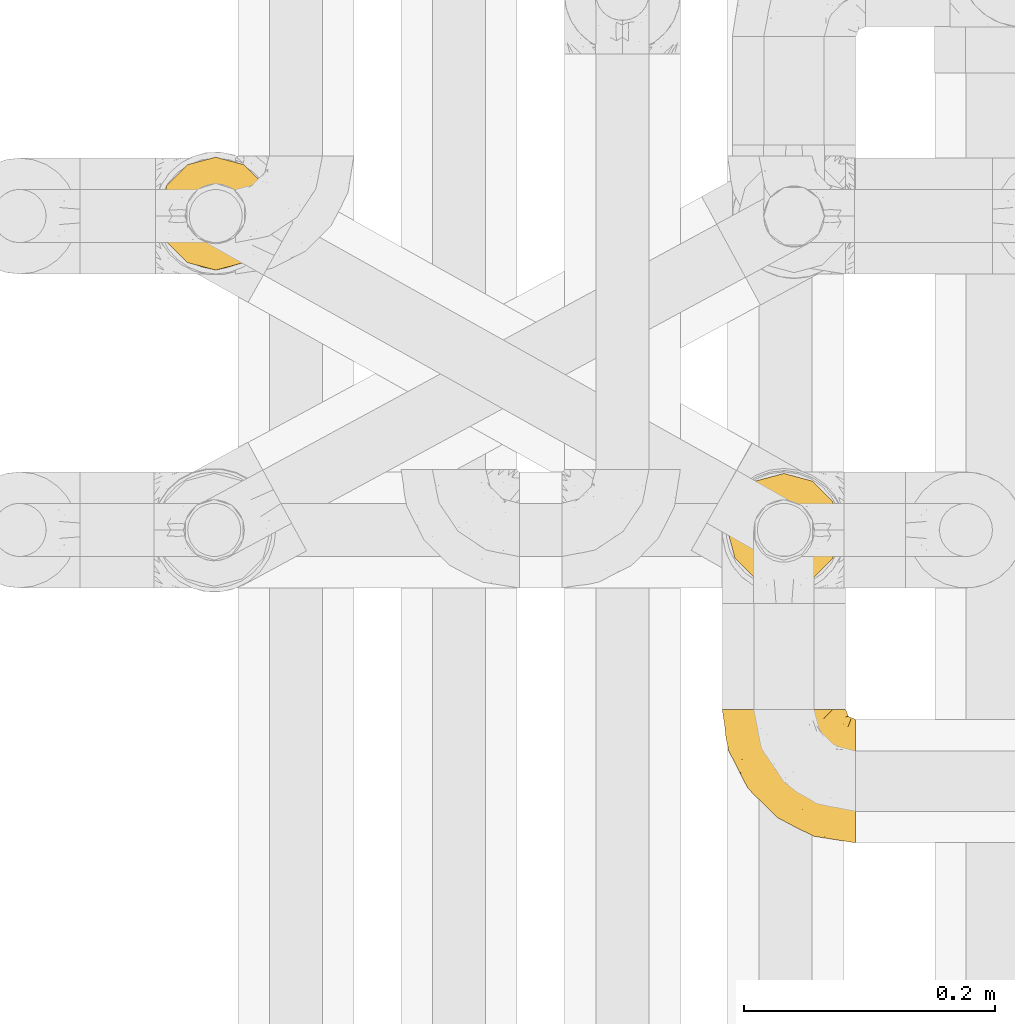
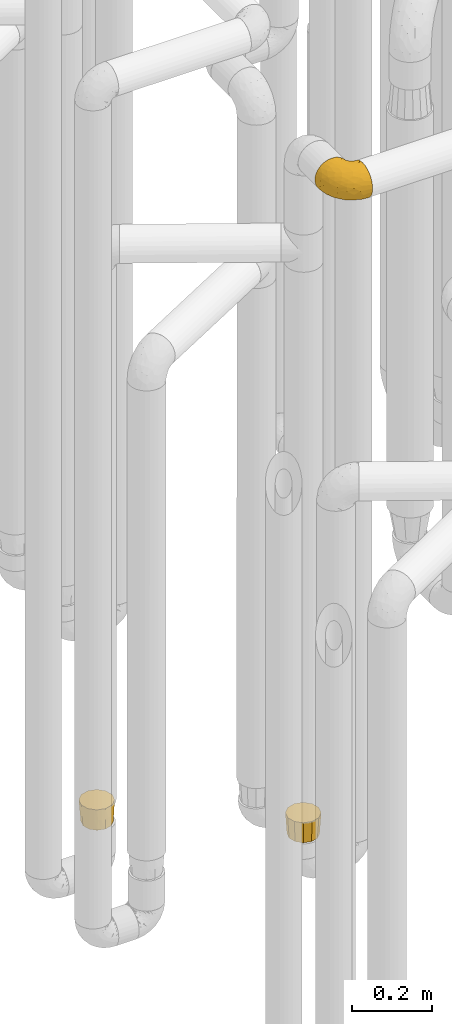
# One storey, part 166 of 827: 3 coverings.
"""IFC2X3 building model written with IfcOpenShell, lengths in millimetres."""

from ifc_helpers import new_model, entity, si_unit, converted_unit, derived_unit, direction, frame, origin, place, context, subcontext, project, spatial, faceted_brep, element, save


model = new_model("IFC2X3")

# Units and contexts
model_context = context("Model", 3, precision=0.01, world=origin(), true_north=direction((6.12303176911189e-17, 1.0)))
body_context = subcontext(model_context, "Body", "Model", "MODEL_VIEW")
ifc_project = project(units=[si_unit("LENGTHUNIT", "METRE", prefix="MILLI"), si_unit("AREAUNIT", "SQUARE_METRE"), si_unit("VOLUMEUNIT", "CUBIC_METRE"), converted_unit("PLANEANGLEUNIT", "DEGREE", entity("IfcRatioMeasure", 0.0174532925199433), si_unit("PLANEANGLEUNIT", "RADIAN"), dimensions=[0, 0, 0, 0, 0, 0, 0]), si_unit("MASSUNIT", "GRAM", prefix="KILO"), derived_unit("MASSDENSITYUNIT", [(si_unit("MASSUNIT", "GRAM", prefix="KILO"), 1), (si_unit("LENGTHUNIT", "METRE"), -3)]), derived_unit("MOMENTOFINERTIAUNIT", [(si_unit("LENGTHUNIT", "METRE"), 4)]), si_unit("TIMEUNIT", "SECOND"), si_unit("FREQUENCYUNIT", "HERTZ"), si_unit("THERMODYNAMICTEMPERATUREUNIT", "DEGREE_CELSIUS"), derived_unit("THERMALTRANSMITTANCEUNIT", [(si_unit("MASSUNIT", "GRAM", prefix="KILO"), 1), (si_unit("THERMODYNAMICTEMPERATUREUNIT", "KELVIN"), -1), (si_unit("TIMEUNIT", "SECOND"), -3)]), derived_unit("VOLUMETRICFLOWRATEUNIT", [(si_unit("LENGTHUNIT", "METRE"), 3), (si_unit("TIMEUNIT", "SECOND"), -1)]), derived_unit("MASSFLOWRATEUNIT", [(si_unit("MASSUNIT", "GRAM", prefix="KILO"), 1), (si_unit("TIMEUNIT", "SECOND"), -1)]), derived_unit("ROTATIONALFREQUENCYUNIT", [(si_unit("TIMEUNIT", "SECOND"), -1)]), si_unit("ELECTRICCURRENTUNIT", "AMPERE"), si_unit("ELECTRICVOLTAGEUNIT", "VOLT"), si_unit("POWERUNIT", "WATT"), si_unit("FORCEUNIT", "NEWTON", prefix="KILO"), si_unit("ILLUMINANCEUNIT", "LUX"), si_unit("LUMINOUSFLUXUNIT", "LUMEN"), si_unit("LUMINOUSINTENSITYUNIT", "CANDELA"), derived_unit("USERDEFINED", [(si_unit("MASSUNIT", "GRAM", prefix="KILO"), -1), (si_unit("LENGTHUNIT", "METRE"), -2), (si_unit("TIMEUNIT", "SECOND"), 3), (si_unit("LUMINOUSFLUXUNIT", "LUMEN"), 1)]), derived_unit("LINEARVELOCITYUNIT", [(si_unit("LENGTHUNIT", "METRE"), 1), (si_unit("TIMEUNIT", "SECOND"), -1)]), si_unit("PRESSUREUNIT", "PASCAL"), derived_unit("USERDEFINED", [(si_unit("LENGTHUNIT", "METRE"), -2), (si_unit("MASSUNIT", "GRAM", prefix="KILO"), 1), (si_unit("TIMEUNIT", "SECOND"), -2)]), derived_unit("LINEARFORCEUNIT", [(si_unit("MASSUNIT", "GRAM", prefix="KILO"), 1), (si_unit("LENGTHUNIT", "METRE"), 1), (si_unit("TIMEUNIT", "SECOND"), -2), (si_unit("LENGTHUNIT", "METRE"), -1)]), derived_unit("PLANARFORCEUNIT", [(si_unit("MASSUNIT", "GRAM", prefix="KILO"), 1), (si_unit("LENGTHUNIT", "METRE"), 1), (si_unit("TIMEUNIT", "SECOND"), -2), (si_unit("LENGTHUNIT", "METRE"), -2)])], contexts=[model_context])

# Site, building, storey
site_placement = place(None, origin())
site = spatial("IfcSite", under=ifc_project, at=site_placement, CompositionType="ELEMENT")
building_placement = place(site_placement, origin())
building = spatial("IfcBuilding", under=site, at=building_placement, CompositionType="ELEMENT")
storey_placement = place(building_placement, frame((0.0, 0.0, 28200.0)))
storey = spatial("IfcBuildingStorey", under=building, at=storey_placement, Name="08", CompositionType="ELEMENT", Elevation=28200.0)

# Coverings
covering_1_placement = place(storey_placement, frame((35678.04, 11305.34, 2549.25)))
element("IfcCovering", 1, at=covering_1_placement, inside=storey, Name=":ADSK_", ObjectType=":ADSK_", PredefinedType="INSULATION", context=body_context, shape_type="Brep", body=[
    faceted_brep([(107.75, 50.75, 99.9), (107.75, 39.8, 98.66), (107.75, 29.41, 95.02), (107.75, 20.09, 89.17), (107.75, 12.31, 81.38), (107.75, 6.46, 72.06), (107.75, 2.83, 61.68), (107.75, 1.6, 50.75), (107.75, 2.83, 39.8), (107.75, 6.47, 29.41), (107.75, 12.32, 20.09), (107.75, 20.11, 12.31), (107.75, 29.43, 6.46), (107.75, 39.81, 2.83), (107.75, 50.75, 1.6), (107.75, 56.45, 2.24), (107.75, 61.69, 2.83), (107.75, 66.88, 4.65), (107.75, 72.08, 6.47), (107.75, 81.4, 12.32), (107.75, 89.18, 20.11), (107.75, 95.03, 29.43), (107.75, 98.66, 39.81), (107.75, 99.9, 50.75), (107.75, 98.66, 61.69), (107.75, 95.02, 72.08), (107.75, 89.17, 81.4), (107.75, 81.38, 89.18), (107.75, 72.06, 95.03), (107.75, 66.87, 96.85), (107.75, 61.68, 98.66), (107.75, 56.45, 99.25), (107.75, 53.6, 99.57), (98.22, 107.75, 38.02), (93.31, 107.75, 26.17), (89.4, 107.75, 21.08), (85.5, 107.75, 15.99), (80.41, 107.75, 12.09), (75.32, 107.75, 8.18), (69.39, 107.75, 5.73), (63.47, 107.75, 3.27), (56.48, 107.75, 2.35), (53.61, 107.75, 1.97), (50.75, 107.75, 1.6), (38.02, 107.75, 3.27), (26.17, 107.75, 8.18), (15.99, 107.75, 15.99), (8.18, 107.75, 26.17), (3.27, 107.75, 38.02), (1.6, 107.75, 50.75), (3.27, 107.75, 63.47), (8.18, 107.75, 75.32), (15.99, 107.75, 85.5), (26.17, 107.75, 93.31), (38.02, 107.75, 98.22), (50.75, 107.75, 99.9), (56.48, 107.75, 99.14), (63.47, 107.75, 98.22), (69.39, 107.75, 95.77), (75.32, 107.75, 93.31), (80.41, 107.75, 89.4), (85.5, 107.75, 85.5), (89.4, 107.75, 80.41), (93.31, 107.75, 75.32), (98.22, 107.75, 63.47), (99.9, 107.75, 50.75), (27.53, 39.38, 59.31), (25.32, 49.75, 73.08), (16.29, 57.38, 63.72), (6.79, 74.94, 50.75), (4.51, 85.97, 58.64), (3.51, 95.66, 50.75), (17.47, 67.82, 76.74), (7.6, 83.09, 67.68), (12.27, 89.16, 78.92), (70.89, 37.01, 94.31), (87.17, 43.46, 98.76), (67.3, 51.79, 98.4), (31.65, 85.58, 94.57), (33.58, 62.84, 89.91), (47.23, 62.77, 96.32), (43.26, 88.17, 98.79), (55.08, 85.93, 99.9), (53.99, 91.42, 99.9), (52.9, 96.91, 99.9), (52.36, 99.62, 99.9), (51.82, 102.33, 99.9), (21.5, 82.57, 87.31), (89.94, 32.75, 95.61), (60.45, 13.79, 60.43), (83.0, 6.77, 65.24), (64.79, 16.46, 72.87), (85.93, 55.08, 99.9), (81.31, 58.17, 99.9), (76.69, 61.26, 99.9), (72.06, 64.35, 99.9), (67.44, 67.44, 99.9), (88.74, 24.18, 90.65), (45.98, 23.37, 63.14), (47.13, 49.76, 91.89), (89.4, 9.84, 75.25), (95.66, 3.51, 50.75), (28.5, 55.75, 82.18), (42.81, 42.34, 85.08), (38.28, 37.78, 76.93), (45.35, 21.87, 50.75), (33.61, 33.61, 50.75), (82.57, 17.1, 83.02), (105.04, 51.28, 99.9), (102.33, 51.82, 99.9), (96.91, 52.9, 99.9), (91.42, 53.99, 99.9), (65.92, 28.01, 87.13), (53.11, 28.99, 80.85), (54.37, 69.9, 99.17), (74.94, 6.79, 50.75), (64.35, 72.06, 99.9), (61.26, 76.69, 99.9), (58.17, 81.31, 99.9), (21.87, 45.35, 50.75), (34.79, 34.79, 67.61), (48.48, 25.72, 72.25), (60.15, 14.33, 50.75), (14.33, 60.15, 50.75), (99.07, 62.38, 98.69), (60.55, 100.57, 99.01), (64.18, 91.06, 98.79), (64.36, 97.66, 98.29), (103.17, 97.55, 68.51), (101.69, 93.65, 76.82), (87.75, 66.85, 98.54), (89.38, 61.93, 99.3), (88.34, 101.4, 83.57), (82.14, 100.07, 89.47), (94.51, 101.36, 75.76), (89.64, 95.94, 84.86), (98.41, 96.3, 75.89), (99.71, 101.98, 64.77), (89.37, 85.88, 90.83), (88.21, 78.88, 94.62), (95.2, 82.8, 90.37), (79.14, 102.58, 91.18), (101.22, 82.88, 88.65), (99.41, 88.57, 84.11), (84.72, 88.67, 91.75), (97.47, 69.08, 96.86), (102.19, 102.19, 50.75), (104.02, 100.06, 58.97), (82.66, 70.56, 98.37), (95.42, 91.07, 83.91), (78.67, 77.56, 97.52), (72.69, 96.59, 95.55), (66.46, 86.38, 98.76), (75.3, 91.79, 95.26), (72.74, 81.71, 98.04), (82.93, 94.11, 90.65), (99.27, 76.09, 93.51), (93.51, 76.91, 94.16), (67.35, 81.44, 99.1), (94.51, 101.37, 25.73), (82.94, 94.12, 10.84), (88.33, 101.41, 17.92), (89.64, 95.96, 16.64), (103.62, 96.22, 30.44), (87.74, 66.85, 2.95), (89.38, 61.94, 2.19), (81.31, 58.17, 1.6), (97.47, 69.1, 4.63), (99.41, 88.58, 17.39), (51.28, 105.04, 1.6), (52.9, 96.91, 1.6), (51.82, 102.33, 1.6), (101.21, 82.9, 12.86), (95.19, 82.82, 11.13), (64.36, 97.66, 3.2), (72.69, 96.59, 5.94), (79.14, 102.58, 10.31), (99.28, 76.13, 8.0), (93.51, 76.93, 7.34), (60.55, 100.57, 2.48), (66.46, 86.38, 2.73), (63.96, 90.86, 2.64), (96.91, 52.9, 1.6), (99.06, 62.39, 2.8), (99.7, 101.98, 36.71), (53.99, 91.42, 1.6), (55.08, 85.93, 1.6), (103.3, 99.49, 38.59), (102.33, 51.82, 1.6), (99.62, 52.36, 1.6), (76.69, 61.26, 1.6), (82.66, 70.56, 3.12), (95.42, 91.09, 17.59), (72.06, 64.35, 1.6), (78.68, 77.6, 3.98), (88.2, 78.89, 6.87), (72.75, 81.71, 3.45), (84.74, 88.69, 9.76), (91.42, 53.99, 1.6), (85.93, 55.08, 1.6), (98.41, 96.31, 25.62), (89.37, 85.9, 10.67), (67.35, 81.45, 2.39), (61.26, 76.69, 1.6), (75.3, 91.79, 6.23), (82.13, 100.07, 12.02), (58.17, 81.31, 1.6), (64.35, 72.06, 1.6), (67.44, 67.44, 1.6), (54.08, 69.6, 2.4), (4.51, 85.97, 42.85), (21.5, 82.57, 14.18), (33.43, 63.16, 11.56), (28.5, 55.81, 19.27), (17.47, 67.81, 24.75), (25.36, 49.73, 28.37), (90.18, 32.55, 5.95), (86.97, 43.23, 2.79), (43.26, 88.17, 2.71), (16.29, 57.38, 37.78), (7.6, 83.08, 33.81), (12.27, 89.16, 22.57), (31.65, 85.58, 6.92), (64.79, 16.46, 28.61), (83.0, 6.77, 36.24), (60.44, 13.8, 41.05), (38.35, 37.71, 24.55), (34.8, 34.8, 33.88), (71.54, 36.83, 7.11), (45.94, 23.39, 38.38), (27.53, 39.38, 42.18), (82.57, 17.12, 18.46), (88.74, 24.19, 10.84), (53.19, 28.89, 20.69), (48.49, 25.69, 29.27), (67.28, 51.77, 3.1), (52.32, 45.66, 9.18), (89.4, 9.85, 26.23), (65.75, 28.11, 14.34), (46.73, 62.27, 5.46), (42.82, 42.35, 16.39)], [[[0, 1, 2, 3, 4, 5, 6, 7, 8, 9, 10, 11, 12, 13, 14, 15, 16, 17, 18, 19, 20, 21, 22, 23, 24, 25, 26, 27, 28, 29, 30, 31, 32]], [[33, 34, 35, 36, 37, 38, 39, 40, 41, 42, 43, 44, 45, 46, 47, 48, 49, 50, 51, 52, 53, 54, 55, 56, 57, 58, 59, 60, 61, 62, 63, 64, 65]], [[66, 67, 68]], [[69, 70, 71]], [[68, 72, 73]], [[73, 72, 74]], [[75, 76, 77]], [[78, 79, 80]], [[51, 50, 73]], [[81, 82, 83, 84, 85, 86, 55]], [[52, 87, 53]], [[74, 52, 51]], [[2, 1, 88]], [[89, 90, 91]], [[77, 92, 93, 94, 95, 96]], [[55, 54, 81]], [[78, 53, 87]], [[5, 90, 6]], [[88, 76, 75]], [[97, 3, 2]], [[89, 91, 98]], [[99, 80, 79]], [[90, 5, 100]], [[74, 87, 52]], [[100, 5, 4]], [[90, 101, 6]], [[79, 102, 103]], [[102, 67, 104]], [[105, 98, 106]], [[107, 4, 3]], [[76, 0, 108, 109, 110, 111, 92]], [[107, 112, 113]], [[114, 77, 96]], [[89, 115, 90]], [[114, 96, 116, 117, 118, 82]], [[75, 97, 88]], [[119, 66, 68]], [[50, 71, 70]], [[100, 91, 90]], [[99, 77, 80]], [[102, 104, 103]], [[97, 107, 3]], [[80, 81, 78]], [[107, 97, 112]], [[68, 73, 70]], [[66, 98, 120]], [[78, 81, 54]], [[114, 81, 80]], [[53, 78, 54]], [[78, 87, 79]], [[102, 87, 72]], [[79, 103, 99]], [[4, 107, 100]], [[91, 100, 107]], [[88, 97, 2]], [[112, 97, 75]], [[99, 112, 75]], [[103, 104, 113]], [[91, 121, 98]], [[89, 105, 122, 115]], [[101, 90, 115]], [[101, 7, 6]], [[88, 1, 76]], [[0, 76, 1]], [[92, 77, 76]], [[73, 74, 51]], [[87, 74, 72]], [[81, 114, 82]], [[77, 114, 80]], [[87, 102, 79]], [[67, 102, 72]], [[68, 67, 72]], [[67, 120, 104]], [[120, 121, 104]], [[104, 121, 113]], [[121, 120, 98]], [[91, 107, 113]], [[91, 113, 121]], [[103, 113, 112]], [[66, 119, 106]], [[105, 89, 98]], [[68, 69, 123, 119]], [[98, 66, 106]], [[66, 120, 67]], [[50, 49, 71]], [[50, 70, 73]], [[112, 99, 103]], [[77, 99, 75]], [[69, 68, 70]], [[29, 124, 110]], [[84, 83, 125]], [[126, 82, 118]], [[59, 58, 127]], [[25, 128, 129]], [[130, 93, 131]], [[132, 62, 133]], [[134, 135, 136]], [[137, 65, 64]], [[64, 134, 137]], [[138, 139, 140]], [[111, 110, 124, 92]], [[134, 136, 137]], [[134, 64, 63]], [[141, 61, 60]], [[125, 58, 57]], [[142, 143, 140]], [[142, 26, 143]], [[127, 83, 82]], [[28, 124, 29]], [[108, 0, 32, 31, 30, 110, 109]], [[30, 29, 110]], [[135, 144, 138]], [[28, 145, 124]], [[57, 56, 55, 86, 85, 84]], [[146, 147, 23]], [[24, 23, 147]], [[25, 143, 26]], [[95, 94, 148]], [[24, 128, 25]], [[149, 138, 143]], [[124, 145, 131]], [[127, 58, 125]], [[150, 148, 139]], [[127, 126, 151]], [[151, 59, 127]], [[152, 151, 126]], [[153, 154, 155]], [[153, 133, 141]], [[145, 28, 27]], [[142, 156, 27]], [[157, 148, 130]], [[61, 133, 62]], [[134, 132, 135]], [[147, 128, 24]], [[65, 137, 146]], [[146, 137, 147]], [[128, 137, 136]], [[137, 128, 147]], [[128, 136, 129]], [[149, 129, 136]], [[25, 129, 143]], [[158, 152, 117]], [[152, 118, 117]], [[153, 151, 152]], [[158, 116, 154]], [[144, 150, 138]], [[153, 152, 158]], [[133, 153, 155]], [[133, 155, 132]], [[141, 60, 151]], [[135, 132, 155]], [[134, 63, 132]], [[144, 135, 155]], [[135, 138, 149]], [[155, 154, 144]], [[150, 154, 96]], [[154, 150, 144]], [[148, 94, 130]], [[82, 126, 127]], [[118, 152, 126]], [[150, 96, 95]], [[139, 148, 157]], [[150, 95, 148]], [[93, 92, 131]], [[130, 145, 156]], [[130, 94, 93]], [[84, 125, 57]], [[127, 125, 83]], [[140, 139, 157]], [[150, 139, 138]], [[140, 157, 142]], [[138, 140, 143]], [[156, 142, 157]], [[27, 26, 142]], [[130, 156, 157]], [[145, 27, 156]], [[132, 63, 62]], [[124, 131, 92]], [[130, 131, 145]], [[129, 149, 143]], [[135, 149, 136]], [[153, 141, 151]], [[59, 151, 60]], [[133, 61, 141]], [[116, 96, 154]], [[153, 158, 154]], [[158, 117, 116]], [[34, 33, 159]], [[160, 161, 162]], [[22, 21, 163]], [[164, 165, 166]], [[19, 18, 167]], [[168, 21, 20]], [[169, 43, 42, 41, 40, 170, 171]], [[172, 173, 168]], [[174, 38, 175]], [[176, 37, 36]], [[177, 164, 178]], [[40, 179, 170]], [[180, 181, 175]], [[17, 182, 183]], [[65, 146, 184]], [[185, 174, 186]], [[23, 22, 187]], [[174, 39, 38]], [[15, 14, 188, 189, 182, 16]], [[179, 40, 39]], [[190, 191, 164]], [[192, 163, 168]], [[33, 184, 159]], [[178, 173, 172]], [[193, 194, 191]], [[18, 183, 167]], [[173, 178, 195]], [[196, 197, 194]], [[198, 199, 183, 182]], [[182, 17, 16]], [[18, 17, 183]], [[200, 159, 184]], [[192, 168, 201]], [[187, 163, 200]], [[202, 203, 180]], [[185, 179, 174]], [[160, 204, 205]], [[206, 181, 180]], [[206, 180, 203]], [[199, 165, 183]], [[165, 164, 167]], [[172, 177, 178]], [[200, 192, 162]], [[205, 161, 160]], [[65, 184, 33]], [[163, 187, 22]], [[175, 204, 180]], [[174, 181, 186]], [[204, 196, 202]], [[197, 160, 162]], [[196, 207, 202]], [[205, 204, 176]], [[196, 204, 160]], [[176, 204, 175]], [[205, 35, 161]], [[34, 159, 161]], [[162, 161, 159]], [[200, 162, 159]], [[197, 162, 201]], [[194, 197, 201]], [[196, 160, 197]], [[191, 195, 178]], [[208, 196, 194]], [[186, 181, 206]], [[175, 181, 174]], [[191, 190, 193]], [[193, 208, 194]], [[195, 194, 201]], [[178, 164, 191]], [[168, 163, 21]], [[166, 165, 199]], [[166, 190, 164]], [[187, 200, 184]], [[184, 146, 187]], [[23, 187, 146]], [[174, 179, 39]], [[170, 179, 185]], [[194, 195, 191]], [[173, 201, 168]], [[201, 173, 195]], [[172, 168, 20]], [[20, 19, 172]], [[177, 172, 19]], [[19, 167, 177]], [[164, 177, 167]], [[35, 205, 36]], [[35, 34, 161]], [[183, 165, 167]], [[162, 192, 201]], [[163, 192, 200]], [[175, 38, 37]], [[205, 176, 36]], [[175, 37, 176]], [[204, 202, 180]], [[207, 196, 208]], [[207, 203, 202]], [[209, 186, 206, 203, 207, 208]], [[48, 210, 71]], [[211, 212, 213]], [[214, 213, 215]], [[216, 217, 13]], [[218, 43, 169, 171, 170, 185, 186]], [[219, 220, 214]], [[47, 46, 221]], [[210, 48, 220]], [[211, 222, 212]], [[222, 45, 44]], [[221, 220, 47]], [[47, 220, 48]], [[221, 211, 214]], [[223, 224, 225]], [[211, 46, 45]], [[226, 227, 215]], [[43, 218, 44]], [[217, 216, 228]], [[227, 229, 230]], [[14, 13, 217]], [[224, 9, 8]], [[10, 231, 11]], [[11, 232, 12]], [[233, 223, 234]], [[235, 208, 193, 190, 166, 199]], [[236, 235, 228]], [[222, 44, 218]], [[106, 230, 229]], [[224, 237, 9]], [[232, 238, 228]], [[9, 237, 10]], [[115, 224, 101]], [[239, 235, 236]], [[232, 11, 231]], [[223, 231, 237]], [[224, 8, 101]], [[223, 229, 234]], [[225, 115, 122, 105]], [[216, 12, 232]], [[209, 235, 239]], [[210, 219, 69]], [[219, 214, 215]], [[230, 119, 219]], [[209, 218, 186]], [[239, 212, 222]], [[239, 222, 218]], [[45, 222, 211]], [[236, 212, 239]], [[213, 212, 240]], [[223, 237, 224]], [[231, 10, 237]], [[238, 232, 231]], [[216, 232, 228]], [[233, 231, 223]], [[236, 238, 240]], [[115, 225, 224]], [[234, 229, 227]], [[8, 7, 101]], [[235, 209, 208]], [[218, 209, 239]], [[217, 228, 235]], [[13, 12, 216]], [[235, 199, 217]], [[217, 199, 198, 182, 189, 188, 14]], [[211, 221, 46]], [[220, 221, 214]], [[71, 210, 69]], [[71, 49, 48]], [[219, 210, 220]], [[226, 215, 213]], [[211, 213, 214]], [[226, 213, 240]], [[215, 227, 230]], [[233, 240, 238]], [[234, 227, 226]], [[233, 234, 226]], [[229, 223, 225]], [[240, 233, 226]], [[233, 238, 231]], [[225, 105, 229]], [[229, 105, 106]], [[106, 119, 230]], [[123, 69, 219, 119]], [[215, 230, 219]], [[238, 236, 228]], [[212, 236, 240]]]),
])
covering_2_placement = place(storey_placement, frame((35682.19, 11509.57, 494.96)))
element("IfcCovering", 2, at=covering_2_placement, inside=storey, Name=":ADSK_", ObjectType=":ADSK_", PredefinedType="INSULATION", context=body_context, shape_type="Brep", body=[
    faceted_brep([(46.6, 87.66, 0.08), (56.85, 84.91, 0.08), (67.1, 82.17, 0.08), (74.6, 74.66, 0.07), (82.1, 67.16, 0.06), (84.85, 56.91, 0.05), (87.6, 46.66, 0.04), (84.85, 36.41, 0.03), (82.1, 26.16, 0.02), (74.6, 18.66, 0.01), (67.1, 11.15, 0.01), (56.85, 8.41, 0.0), (46.6, 5.66, 0.0), (36.35, 8.41, 0.0), (26.1, 11.15, 0.01), (18.59, 18.66, 0.01), (11.09, 26.16, 0.02), (8.34, 36.41, 0.03), (5.6, 46.66, 0.04), (8.34, 56.91, 0.05), (11.09, 67.16, 0.06), (18.59, 74.66, 0.07), (26.1, 82.17, 0.08), (36.35, 84.91, 0.08), (7.62, 24.1, 64.02), (15.86, 15.86, 64.01), (24.1, 7.62, 64.0), (33.21, 5.18, 64.0), (46.6, 1.6, 64.0), (59.99, 5.18, 64.0), (69.1, 7.62, 64.0), (77.33, 15.86, 64.01), (85.57, 24.1, 64.02), (88.01, 33.21, 64.03), (91.6, 46.6, 64.04), (88.01, 59.99, 64.05), (85.57, 69.1, 64.06), (77.33, 77.33, 64.07), (69.1, 85.57, 64.08), (59.99, 88.01, 64.08), (46.6, 91.6, 64.09), (33.21, 88.01, 64.08), (24.1, 85.57, 64.08), (15.86, 77.33, 64.07), (7.62, 69.1, 64.06), (5.18, 59.99, 64.05), (1.6, 46.6, 64.04), (5.18, 33.21, 64.03)], [[[0, 1, 2, 3, 4, 5, 6, 7, 8, 9, 10, 11, 12, 13, 14, 15, 16, 17, 18, 19, 20, 21, 22, 23]], [[24, 25, 26, 27, 28, 29, 30, 31, 32, 33, 34, 35, 36, 37, 38, 39, 40, 41, 42, 43, 44, 45, 46, 47]], [[4, 36, 35, 34, 6, 5]], [[38, 37, 36, 4, 3, 2]], [[1, 0, 40, 39, 38, 2]], [[10, 30, 29, 28, 12, 11]], [[32, 31, 30, 10, 9, 8]], [[7, 6, 34, 33, 32, 8]], [[16, 24, 47, 46, 18, 17]], [[26, 25, 24, 16, 15, 14]], [[13, 12, 28, 27, 26, 14]], [[22, 42, 41, 40, 0, 23]], [[44, 43, 42, 22, 21, 20]], [[19, 18, 46, 45, 44, 20]]]),
])
covering_3_placement = place(storey_placement, frame((35229.64, 11761.53, 540.0)))
element("IfcCovering", 3, at=covering_3_placement, inside=storey, Name=":ADSK_", ObjectType=":ADSK_", PredefinedType="INSULATION", context=body_context, shape_type="Brep", body=[
    faceted_brep([(15.86, 15.86, 64.0), (24.1, 7.62, 64.0), (35.35, 4.61, 64.0), (46.6, 1.6, 64.0), (57.85, 4.61, 64.0), (69.1, 7.62, 64.0), (77.33, 15.86, 64.0), (85.57, 24.1, 64.0), (88.58, 35.35, 64.0), (91.6, 46.6, 64.0), (88.58, 57.85, 64.0), (85.57, 69.1, 64.0), (77.33, 77.33, 64.0), (69.1, 85.57, 64.0), (57.85, 88.58, 64.0), (46.6, 91.6, 64.0), (35.35, 88.58, 64.0), (24.1, 85.57, 64.0), (15.86, 77.33, 64.0), (7.62, 69.1, 64.0), (4.61, 57.85, 64.0), (1.6, 46.6, 64.0), (4.61, 35.35, 64.0), (7.62, 24.1, 64.0), (11.09, 65.17, 0.0), (18.59, 72.67, 0.0), (26.1, 80.18, 0.0), (38.81, 83.58, 0.0), (46.6, 85.67, 0.0), (56.85, 82.92, 0.0), (67.1, 80.18, 0.0), (74.6, 72.67, 0.0), (82.1, 65.17, 0.0), (85.51, 52.46, 0.0), (87.6, 44.67, 0.0), (84.85, 34.42, 0.0), (82.1, 24.17, 0.0), (74.6, 16.67, 0.0), (67.1, 9.16, 0.0), (54.39, 5.76, 0.0), (46.6, 3.67, 0.0), (36.35, 6.42, 0.0), (26.1, 9.16, 0.0), (18.59, 16.67, 0.0), (11.09, 24.17, 0.0), (7.68, 36.87, 0.0), (5.6, 44.67, 0.0), (8.34, 54.92, 0.0), (63.05, 5.91, 32.0), (55.0, 3.42, 33.43), (46.6, 2.6, 32.86), (70.94, 10.19, 32.0), (88.25, 34.95, 32.0), (80.71, 19.46, 32.0), (85.4, 27.11, 32.0), (89.65, 45.66, 32.86), (86.32, 62.09, 32.0), (88.86, 54.09, 33.43), (82.04, 69.98, 32.0), (57.28, 87.28, 32.0), (72.77, 79.75, 32.0), (65.12, 84.44, 32.0), (46.6, 88.71, 32.81), (30.14, 85.36, 32.0), (38.19, 87.94, 33.43), (22.25, 81.08, 32.0), (4.94, 56.32, 32.0), (12.48, 71.81, 32.0), (7.79, 64.16, 32.0), (3.54, 45.66, 32.81), (6.87, 29.18, 32.0), (4.33, 37.27, 33.43), (11.15, 21.29, 32.0), (35.91, 3.98, 32.0), (20.42, 11.52, 32.0), (28.07, 6.83, 32.0)], [[[0, 1, 2, 3, 4, 5, 6, 7, 8, 9, 10, 11, 12, 13, 14, 15, 16, 17, 18, 19, 20, 21, 22, 23]], [[24, 25, 26, 27, 28, 29, 30, 31, 32, 33, 34, 35, 36, 37, 38, 39, 40, 41, 42, 43, 44, 45, 46, 47]], [[39, 48, 49]], [[39, 50, 40]], [[48, 39, 38]], [[5, 4, 48]], [[51, 5, 48]], [[48, 4, 49]], [[9, 8, 52]], [[53, 51, 37]], [[51, 48, 38]], [[7, 53, 54]], [[54, 53, 36]], [[37, 36, 53]], [[51, 38, 37]], [[50, 49, 3]], [[53, 6, 51]], [[6, 5, 51]], [[6, 53, 7]], [[52, 8, 54]], [[54, 35, 52]], [[54, 36, 35]], [[3, 49, 4]], [[8, 7, 54]], [[34, 55, 9, 52]], [[39, 49, 50]], [[34, 52, 35]], [[33, 56, 57]], [[33, 55, 34]], [[56, 33, 32]], [[11, 10, 56]], [[58, 11, 56]], [[56, 10, 57]], [[15, 14, 59]], [[60, 58, 31]], [[58, 56, 32]], [[13, 60, 61]], [[61, 60, 30]], [[31, 30, 60]], [[58, 32, 31]], [[55, 57, 9]], [[60, 12, 58]], [[12, 11, 58]], [[12, 60, 13]], [[59, 14, 61]], [[61, 29, 59]], [[61, 30, 29]], [[9, 57, 10]], [[14, 13, 61]], [[28, 62, 15, 59]], [[33, 57, 55]], [[28, 59, 29]], [[27, 63, 64]], [[27, 62, 28]], [[63, 27, 26]], [[17, 16, 63]], [[65, 17, 63]], [[63, 16, 64]], [[21, 20, 66]], [[67, 65, 25]], [[65, 63, 26]], [[19, 67, 68]], [[68, 67, 24]], [[25, 24, 67]], [[65, 26, 25]], [[62, 64, 15]], [[67, 18, 65]], [[18, 17, 65]], [[18, 67, 19]], [[66, 20, 68]], [[68, 47, 66]], [[68, 24, 47]], [[15, 64, 16]], [[20, 19, 68]], [[46, 69, 21, 66]], [[27, 64, 62]], [[46, 66, 47]], [[45, 70, 71]], [[45, 69, 46]], [[70, 45, 44]], [[23, 22, 70]], [[72, 23, 70]], [[70, 22, 71]], [[3, 2, 73]], [[74, 72, 43]], [[72, 70, 44]], [[1, 74, 75]], [[75, 74, 42]], [[43, 42, 74]], [[72, 44, 43]], [[69, 71, 21]], [[74, 0, 72]], [[0, 23, 72]], [[0, 74, 1]], [[73, 2, 75]], [[75, 41, 73]], [[75, 42, 41]], [[21, 71, 22]], [[2, 1, 75]], [[40, 50, 3, 73]], [[45, 71, 69]], [[40, 73, 41]]]),
])

save(model, "model.ifc")
